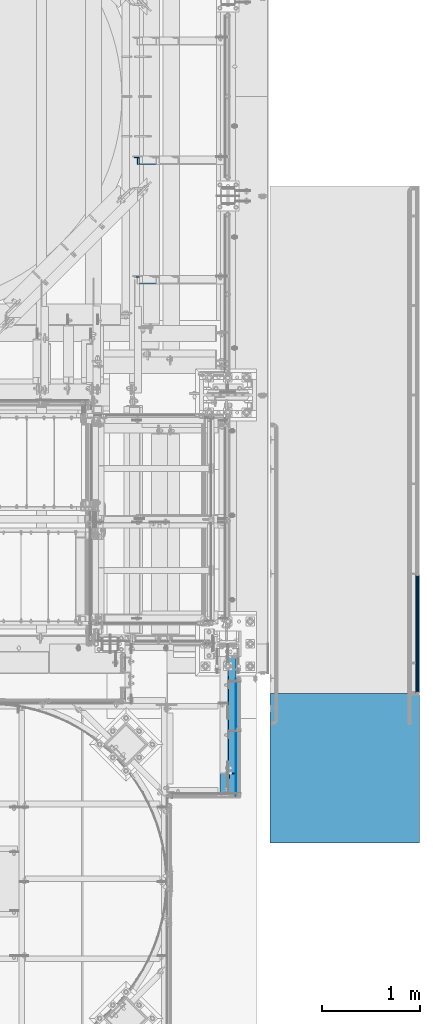
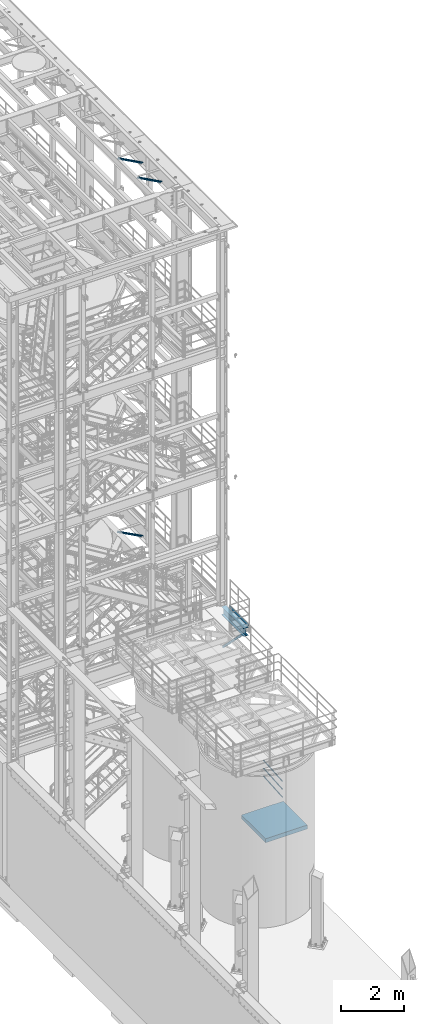
# One storey, part 998 of 1876: 6 beams, 4 members, 8 elements without a shape of their own.
"""IFC2X3 building model written with IfcOpenShell, lengths in millimetres."""

from ifc_helpers import new_model, si_unit, frame, origin_with_axes, place, context, subcontext, project, spatial, faceted_brep, material, type_object, element, aggregate, save


model = new_model("IFC2X3")

# Units and contexts
model_context = context("Model", 3, precision=1e-05, world=origin_with_axes())
body_context = subcontext(model_context, "Body", "Model", "MODEL_VIEW")
ifc_project = project(units=[si_unit("LENGTHUNIT", "METRE", prefix="MILLI"), si_unit("AREAUNIT", "SQUARE_METRE"), si_unit("VOLUMEUNIT", "CUBIC_METRE"), si_unit("MASSUNIT", "GRAM", prefix="KILO"), si_unit("TIMEUNIT", "SECOND"), si_unit("PLANEANGLEUNIT", "RADIAN"), si_unit("SOLIDANGLEUNIT", "STERADIAN"), si_unit("THERMODYNAMICTEMPERATUREUNIT", "DEGREE_CELSIUS"), si_unit("LUMINOUSINTENSITYUNIT", "LUMEN")], contexts=[model_context])

# Site, building, storey
site_placement = place(None, origin_with_axes())
site = spatial("IfcSite", under=ifc_project, at=site_placement, CompositionType="ELEMENT")
building_placement = place(site_placement, origin_with_axes())
building = spatial("IfcBuilding", under=site, at=building_placement, Name="Undefined", CompositionType="ELEMENT")
storey_placement = place(building_placement, origin_with_axes())
storey = spatial("IfcBuildingStorey", under=building, at=storey_placement, Name="Undefined", CompositionType="ELEMENT", Elevation=0.0)

# Assembly, beam
assembly_1_placement = place(storey_placement, origin_with_axes())
assembly_1 = element("IfcElementAssembly", 1, at=assembly_1_placement, inside=storey, Name="HANDRAIL", AssemblyPlace="NOTDEFINED", PredefinedType="RIGID_FRAME")
ifc_material_1 = material(Name="STEEL/A36")
beam_type_1 = type_object("IfcBeamType", PredefinedType="NOTDEFINED")
beam_1_placement = place(assembly_1_placement, frame((7705.725, -8663.432, 8080.375), z_axis=(0.0, 0.0, 1.0), x_axis=(0.0, 1.0, 0.0)))
beam_1 = element("IfcBeam", 2, at=beam_1_placement, type_object=beam_type_1, material=ifc_material_1, Name="PLATE", context=body_context, shape_type="Brep", body=[
    faceted_brep([(0.0, 3.17500000000018, -50.8000000000002), (0.0, 3.17500000000018, 50.8000000000002), (1194.24450076294, 3.17500000000018, 50.8000000000002), (1194.24450076294, 3.17500000000018, -50.8000000000002), (0.0, -3.17500000000018, 50.8000000000002), (1194.24450076294, -3.17500000000018, 50.8000000000002), (0.0, -3.17500000000018, -50.8000000000002), (1194.24450076294, -3.17500000000018, -50.8000000000002)], [[[0, 1, 2, 3]], [[1, 4, 5, 2]], [[4, 6, 7, 5]], [[6, 0, 3, 7]], [[5, 7, 3, 2]], [[6, 4, 1, 0]]]),
])
aggregate(assembly_1, [beam_1])

# Assembly, member
assembly_2_placement = place(storey_placement, origin_with_axes())
assembly_2 = element("IfcElementAssembly", 3, at=assembly_2_placement, inside=storey, Name="ANGLE", AssemblyPlace="NOTDEFINED", PredefinedType="RIGID_FRAME")
member_type = type_object("IfcMemberType", Name="L3X3X3/8", PredefinedType="NOTDEFINED")
member_1_placement = place(assembly_2_placement, frame((7662.86250005337, -8459.78750000608, 7640.6375), z_axis=(1.0, 0.0, 0.0), x_axis=(0.0, 0.707106781186548, -0.707106781186548)))
member_1 = element("IfcMember", 4, at=member_1_placement, type_object=member_type, material=ifc_material_1, Name="ANGLE", ObjectType="L3X3X3/8", context=body_context, shape_type="Brep", body=[
    faceted_brep([(0.0, 38.1000000000004, -38.1), (0.0, 38.1000000000004, 38.1), (1831.97224869938, 38.1000000000057, 38.1000000000004), (1831.97224869938, 38.1000000000057, -38.1000000000004), (0.0, 28.5749999999998, 38.1), (1831.97224869938, 28.5750000000043, 38.1000000000004), (0.0, 28.5749999999998, -28.575), (1831.97224869938, 28.5750000000043, -28.5749999999998), (0.0, -38.1000000000004, -28.575), (1831.97224869938, -38.1000000000068, -28.5749999999998), (0.0, -38.1000000000004, -38.1), (1831.97224869938, -38.1000000000068, -38.1000000000004)], [[[0, 1, 2, 3]], [[1, 4, 5, 2]], [[4, 6, 7, 5]], [[6, 8, 9, 7]], [[8, 10, 11, 9]], [[10, 0, 3, 11]], [[5, 7, 9, 11, 3, 2]], [[10, 8, 6, 4, 1, 0]]]),
])
aggregate(assembly_2, [member_1])

assembly_3_placement = place(storey_placement, origin_with_axes())
assembly_3 = element("IfcElementAssembly", 5, at=assembly_3_placement, inside=storey, AssemblyPlace="NOTDEFINED", PredefinedType="RIGID_FRAME")
member_2_placement = place(assembly_3_placement, frame((6618.98281309327, -2181.225, 8122.54466495056), z_axis=(0.0, -1.0, 0.0), x_axis=(0.882670061850832, 0.0, -0.469993150920573)))
member_2 = element("IfcMember", 6, at=member_2_placement, type_object=member_type, material=ifc_material_1, ObjectType="L3X3X3/8", context=body_context, shape_type="Brep", body=[
    faceted_brep([(70.0788597189262, 38.1000000000258, -38.1), (70.0788597189262, 38.1000000000258, 38.1), (1091.31003699859, 38.1000000003387, 38.1), (1091.31003699859, 38.1000000003387, -38.1), (70.0788597189253, 28.5750000000244, 38.1), (1091.31003699859, 28.5750000003391, 38.1), (70.0788597189253, 28.5750000000244, -28.575), (1091.31003699859, 28.5750000003391, -28.575), (70.0788597189262, -38.0999999999822, -28.575), (1091.31003699859, -38.0999999996675, -28.575), (70.0788597189262, -38.0999999999822, -38.1), (1091.31003699859, -38.0999999996675, -38.1)], [[[0, 1, 2, 3]], [[1, 4, 5, 2]], [[4, 6, 7, 5]], [[6, 8, 9, 7]], [[8, 10, 11, 9]], [[10, 0, 3, 11]], [[5, 7, 9, 11, 3, 2]], [[10, 8, 6, 4, 1, 0]]]),
])
aggregate(assembly_3, [member_2])

assembly_4_placement = place(storey_placement, origin_with_axes())
assembly_4 = element("IfcElementAssembly", 7, at=assembly_4_placement, inside=storey, AssemblyPlace="NOTDEFINED", PredefinedType="RIGID_FRAME")
member_3_placement = place(assembly_4_placement, frame((6649.22451200435, -3400.425, 22521.7692276093), z_axis=(0.0, -1.0, 0.0), x_axis=(0.877448093107094, 0.0, -0.479671600058544)))
member_3 = element("IfcMember", 8, at=member_3_placement, type_object=member_type, material=ifc_material_1, ObjectType="L3X3X3/8", context=body_context, shape_type="Brep", body=[
    faceted_brep([(59.7482362440578, 38.0999999998749, -38.0999999999999), (59.7482362440578, 38.0999999998749, 38.0999999999999), (1062.91900040893, 38.0999999984488, 38.0999999999999), (1062.91900040893, 38.0999999984488, -38.0999999999999), (59.7482362440696, 28.5749999998843, 38.0999999999999), (1062.91900040895, 28.5749999984582, 38.0999999999999), (59.7482362440696, 28.5749999998843, -28.5749999999998), (1062.91900040895, 28.5749999984582, -28.5749999999998), (59.7482362441442, -38.1000000000495, -28.5749999999998), (1062.91900040902, -38.1000000014719, -28.5749999999998), (59.7482362441442, -38.1000000000495, -38.0999999999999), (1062.91900040902, -38.1000000014719, -38.0999999999999)], [[[0, 1, 2, 3]], [[1, 4, 5, 2]], [[4, 6, 7, 5]], [[6, 8, 9, 7]], [[8, 10, 11, 9]], [[10, 0, 3, 11]], [[5, 7, 9, 11, 3, 2]], [[10, 8, 6, 4, 1, 0]]]),
])
aggregate(assembly_4, [member_3])

assembly_5_placement = place(storey_placement, origin_with_axes())
assembly_5 = element("IfcElementAssembly", 9, at=assembly_5_placement, inside=storey, AssemblyPlace="NOTDEFINED", PredefinedType="RIGID_FRAME")
member_4_placement = place(assembly_5_placement, frame((6649.22451200435, -2181.225, 22521.7692276093), z_axis=(0.0, -1.0, 0.0), x_axis=(0.877448093107094, 0.0, -0.479671600058544)))
member_4 = element("IfcMember", 10, at=member_4_placement, type_object=member_type, material=ifc_material_1, ObjectType="L3X3X3/8", context=body_context, shape_type="Brep", body=[
    faceted_brep([(59.7482362440578, 38.0999999998749, -38.0999999999999), (59.7482362440578, 38.0999999998749, 38.0999999999999), (1062.91900040893, 38.0999999984488, 38.0999999999999), (1062.91900040893, 38.0999999984488, -38.0999999999999), (59.7482362440696, 28.5749999998843, 38.0999999999999), (1062.91900040895, 28.5749999984582, 38.0999999999999), (59.7482362440696, 28.5749999998843, -28.5749999999998), (1062.91900040895, 28.5749999984582, -28.5749999999998), (59.7482362441442, -38.1000000000495, -28.5749999999998), (1062.91900040902, -38.1000000014719, -28.5749999999998), (59.7482362441442, -38.1000000000495, -38.0999999999999), (1062.91900040902, -38.1000000014719, -38.0999999999999)], [[[0, 1, 2, 3]], [[1, 4, 5, 2]], [[4, 6, 7, 5]], [[6, 8, 9, 7]], [[8, 10, 11, 9]], [[10, 0, 3, 11]], [[5, 7, 9, 11, 3, 2]], [[10, 8, 6, 4, 1, 0]]]),
])
aggregate(assembly_5, [member_4])

# Assembly, beam
assembly_6_placement = place(storey_placement, origin_with_axes())
assembly_6 = element("IfcElementAssembly", 11, at=assembly_6_placement, inside=storey, Name="BEAM", AssemblyPlace="NOTDEFINED", PredefinedType="RIGID_FRAME")
ifc_material_2 = material(Name="STEEL/A992")
beam_type_2 = type_object("IfcBeamType", Name="W12X26", PredefinedType="NOTDEFINED")
beam_2_placement = place(assembly_6_placement, frame((7620.0, -8661.4, 7842.25), z_axis=(0.0, 0.0, 1.0), x_axis=(0.0, 1.0, 0.0)))
beam_2 = element("IfcBeam", 12, at=beam_2_placement, type_object=beam_type_2, material=ifc_material_2, Name="BEAM", ObjectType="W12X26", context=body_context, shape_type="Brep", body=[
    faceted_brep([(0.0, 82.5500000000002, -155.575), (0.0, 82.5500000000002, -146.05), (1406.525, 82.5500000000002, -146.05), (1406.525, 82.5500000000002, -155.575), (0.0, 3.17500000000018, -146.05), (1406.525, 3.17500000000018, -146.05), (0.0, 3.17500000000018, 146.05), (1406.525, 3.17500000000018, 146.05), (0.0, 82.5500000000002, 146.05), (1406.525, 82.5500000000002, 146.05), (0.0, 82.5500000000002, 155.575), (1406.525, 82.5500000000002, 155.575), (0.0, -82.5500000000002, 155.575), (1406.525, -82.5500000000002, 155.575), (0.0, -82.5500000000002, 146.05), (1406.525, -82.5500000000002, 146.05), (0.0, -3.17500000000018, 146.05), (1406.525, -3.17500000000018, 146.05), (0.0, -3.17500000000018, -146.05), (1406.525, -3.17500000000018, -146.05), (0.0, -82.5500000000002, -146.05), (1406.525, -82.5500000000002, -146.05), (0.0, -82.5500000000002, -155.575), (1406.525, -82.5500000000002, -155.575)], [[[0, 1, 2, 3]], [[1, 4, 5, 2]], [[4, 6, 7, 5]], [[6, 8, 9, 7]], [[8, 10, 11, 9]], [[10, 12, 13, 11]], [[12, 14, 15, 13]], [[14, 16, 17, 15]], [[16, 18, 19, 17]], [[18, 20, 21, 19]], [[20, 22, 23, 21]], [[22, 0, 3, 23]], [[5, 7, 9, 11, 13, 15, 17, 19, 21, 23, 3, 2]], [[22, 20, 18, 16, 14, 12, 10, 8, 6, 4, 1, 0]]]),
])
aggregate(assembly_6, [beam_2])

# Assembly, beams
assembly_7_placement = place(storey_placement, origin_with_axes())
assembly_7 = element("IfcElementAssembly", 13, at=assembly_7_placement, inside=storey, Name="RAIL", AssemblyPlace="NOTDEFINED", PredefinedType="RIGID_FRAME")
ifc_material_3 = material()
beam_type_3 = type_object("IfcBeamType", PredefinedType="NOTDEFINED")
beam_3_placement = place(assembly_7_placement, frame((9556.75019531245, -7620.00000000011, 152.399999999655), z_axis=(0.0, -0.072723596972548, 0.997352133623513), x_axis=(0.0, 0.997352133623513, 0.0727235969725478)))
beam_3 = element("IfcBeam", 14, at=beam_3_placement, type_object=beam_type_3, material=ifc_material_3, Name="RAIL", context=body_context, shape_type="Brep", body=[
    faceted_brep([(1207.0982290601, -9.52499999999964, 16.497783942101), (1206.78197993275, -9.52500000005239, 12.1606532850326), (1206.47123649284, -7.9375, 13.7481532850854), (1204.49382580197, 0.0, 15.8750000000074), (1204.72533623104, 0.0, 19.0500000000073), (1206.47123649287, 7.9375, 13.7481532850854), (1206.78197993276, 9.52499999994689, 12.1606532851381), (1207.0982290601, 9.52499999999964, 16.497783942101), (1222.43684945429, 19.0499999999993, 7.61701812734827e-12), (1213.58109283001, 16.4977839420935, 9.52500000000748), (1212.1920302556, 16.4977839420935, -9.52499999999236), (1210.70840697457, 13.7481532850779, 7.9375000000075), (1212.26212417405, 15.875, 7.50333128962666e-12), (1209.55085482922, 13.7481532850779, -7.9374999999925), (1205.00855123367, 9.52499999994689, -12.1606532851231), (1204.69230210633, 9.52499999999964, -16.497783942086), (1204.46629736472, 7.9375, -13.7481532850704), (1202.17872151129, 0.0, -15.8749999999924), (1201.94721108222, 0.0, -19.0499999999925), (1205.00855123368, -9.52500000005239, -12.1606532850176), (1204.69230210633, -9.52499999999964, -16.497783942086), (1204.4662973647, -7.9375, -13.7481532850704), (1222.43684942911, -19.050000000052, 1.84320469998056e-09), (1212.1920302556, -16.4977839420935, -9.52499999999247), (1213.58109283001, -16.4977839420935, 9.52500000000748), (1209.55085482912, -13.7481532850779, -7.9374999999925), (1212.26212417395, -15.875, 7.50333128962666e-12), (1210.70840697446, -13.7481532850779, 7.9375000000075), (8.85575659753249, -16.4977839420935, -9.52499999999998), (15.3386203674418, -9.52499999999964, -16.4977839420934), (-9.09494701772928e-13, 19.05, -1.81898940354586e-12), (8.85575659753249, 16.4977839420935, -9.52499999999998), (10.244819171945, 16.4977839420935, 9.52499999999998), (17.7445473212156, 9.52499999999964, 16.4977839420935), (20.489638345327, -1.41153577715158e-09, 19.05), (15.3386203674418, 9.52499999999964, -16.4977839420934), (17.7115131965011, 0.0, -19.0499999999998), (17.9430236255703, 0.0, -15.8749999999998), (15.6548694948933, -9.52500000141117, -12.1606532836663), (15.9656129350642, -7.9375, -13.7481532850779), (15.9656129343048, 7.9375, -13.7481532850778), (15.6548694946878, 9.5249999985881, -12.1606532864894), (11.7284424516083, 13.7481532850779, -7.9375), (10.1747252521245, 15.875, 0.0), (12.8859945969516, 13.7481532850779, 7.9375), (17.4282981939696, 9.5249999985881, 12.1606532864895), (17.9705520624493, 7.9375, 13.7481532850779), (20.2581279162578, -1.41153577715158e-09, 15.875), (17.9705520632106, -7.9375, 13.7481532850779), (17.428298193764, -9.52500000141117, 12.1606532836664), (17.7445473212156, -9.52499999999964, 16.4977839420935), (10.244819171945, -16.4977839420935, 9.52499999999998), (0.0, -19.0500000000002, 0.0), (12.8859945997865, -13.7481532850779, 7.9375), (10.1747252549585, -15.875, 0.0), (11.7284424544423, -13.7481532850779, -7.9375)], [[[0, 1, 2, 3, 4]], [[4, 3, 5, 6, 7]], [[8, 9, 10]], [[7, 6, 11, 12, 13, 14, 15, 10, 9]], [[16, 17, 18, 15, 14]], [[19, 20, 18, 17, 21]], [[22, 23, 24]], [[24, 23, 20, 19, 25, 26, 27, 1, 0]], [[28, 29, 20, 23]], [[30, 31, 32]], [[33, 34, 4, 7]], [[32, 33, 7, 9]], [[30, 32, 9, 8]], [[31, 30, 8, 10]], [[35, 31, 10, 15]], [[36, 35, 15, 18]], [[29, 36, 18, 20]], [[37, 36, 29, 38, 39]], [[40, 41, 35, 36, 37]], [[32, 31, 35, 41, 42, 43, 44, 45, 33]], [[33, 45, 46, 47, 34]], [[34, 47, 48, 49, 50]], [[34, 50, 0, 4]], [[50, 51, 24, 0]], [[51, 52, 22, 24]], [[52, 28, 23, 22]], [[51, 28, 52]], [[50, 49, 53, 54, 55, 38, 29, 28, 51]], [[55, 54, 26, 25]], [[21, 39, 38, 55, 25, 19]], [[37, 39, 21, 17]], [[40, 37, 17, 16]], [[42, 41, 40, 16, 14, 13]], [[43, 42, 13, 12]], [[44, 43, 12, 11]], [[5, 46, 45, 44, 11, 6]], [[47, 46, 5, 3]], [[48, 47, 3, 2]], [[53, 49, 48, 2, 1, 27]], [[54, 53, 27, 26]]]),
])
ifc_material_4 = material()
beam_4_placement = place(assembly_7_placement, frame((9556.75019531097, -6400.80000000011, 546.100005085843), z_axis=(0.0, 0.072723596972548, -0.997352133623513), x_axis=(0.0, -0.997352133623513, -0.0727235969725479)))
beam_4 = element("IfcBeam", 15, at=beam_4_placement, type_object=beam_type_3, material=ifc_material_4, Name="RAIL", context=body_context, shape_type="Brep", body=[
    faceted_brep([(-9.09494701772928e-13, 19.05, -1.81898940354586e-12), (8.85575659753249, 16.4977839420935, -9.52499999999998), (10.244819171945, 16.4977839420935, 9.52499999999998), (10.244819171945, -16.4977839420935, 9.52499999999998), (8.85575659753249, -16.4977839420935, -9.52499999999998), (0.0, -19.0500000000002, 0.0), (17.7445473212156, -9.52499999999964, 16.4977839420935), (17.428298193764, -9.52500000141117, 12.1606532836664), (12.8859945997865, -13.7481532850779, 7.9375), (10.1747252549585, -15.875, 0.0), (11.7284424544423, -13.7481532850779, -7.9375), (15.6548694948933, -9.52500000141117, -12.1606532836663), (15.3386203674418, -9.52499999999964, -16.4977839420934), (17.9430236255703, 0.0, -15.8749999999998), (17.7115131965011, 0.0, -19.0499999999998), (15.9656129350642, -7.9375, -13.7481532850779), (15.9656129343048, 7.9375, -13.7481532850778), (15.6548694946878, 9.5249999985881, -12.1606532864894), (15.3386203674418, 9.52499999999964, -16.4977839420934), (11.7284424516083, 13.7481532850779, -7.9375), (10.1747252521245, 15.875, 0.0), (12.8859945969516, 13.7481532850779, 7.9375), (17.4282981939696, 9.5249999985881, 12.1606532864895), (17.7445473212156, 9.52499999999964, 16.4977839420935), (17.9705520624493, 7.9375, 13.7481532850779), (20.2581279162578, -1.41153577715158e-09, 15.875), (20.489638345327, -1.41153577715158e-09, 19.05), (17.9705520632106, -7.9375, 13.7481532850779), (1222.43684945429, 19.0499999999993, 7.61701812734827e-12), (1212.1920302556, 16.4977839420935, -9.52499999999236), (1204.69230210633, 9.52499999999964, -16.497783942086), (1222.43684942911, -19.050000000052, 1.84320469998056e-09), (1212.1920302556, -16.4977839420935, -9.52499999999247), (1213.58109283001, -16.4977839420935, 9.52500000000748), (1207.0982290601, -9.52499999999964, 16.497783942101), (1204.69230210633, -9.52499999999964, -16.497783942086), (1201.94721108222, 0.0, -19.0499999999925), (1204.46629736472, 7.9375, -13.7481532850704), (1202.17872151129, 0.0, -15.8749999999924), (1205.00855123367, 9.52499999994689, -12.1606532851231), (1205.00855123368, -9.52500000005239, -12.1606532850176), (1204.4662973647, -7.9375, -13.7481532850704), (1209.55085482912, -13.7481532850779, -7.9374999999925), (1212.26212417395, -15.875, 7.50333128962666e-12), (1210.70840697446, -13.7481532850779, 7.9375000000075), (1206.78197993275, -9.52500000005239, 12.1606532850326), (1206.47123649284, -7.9375, 13.7481532850854), (1204.49382580197, 0.0, 15.8750000000074), (1204.72533623104, 0.0, 19.0500000000073), (1207.0982290601, 9.52499999999964, 16.497783942101), (1213.58109283001, 16.4977839420935, 9.52500000000748), (1206.78197993276, 9.52499999994689, 12.1606532851381), (1210.70840697457, 13.7481532850779, 7.9375000000075), (1212.26212417405, 15.875, 7.50333128962666e-12), (1209.55085482922, 13.7481532850779, -7.9374999999925), (1206.47123649287, 7.9375, 13.7481532850854)], [[[0, 1, 2]], [[3, 4, 5]], [[6, 7, 8, 9, 10, 11, 12, 4, 3]], [[13, 14, 12, 11, 15]], [[16, 17, 18, 14, 13]], [[2, 1, 18, 17, 19, 20, 21, 22, 23]], [[23, 22, 24, 25, 26]], [[26, 25, 27, 7, 6]], [[1, 0, 28, 29]], [[18, 1, 29, 30]], [[31, 32, 33]], [[6, 3, 33, 34]], [[3, 5, 31, 33]], [[5, 4, 32, 31]], [[4, 12, 35, 32]], [[12, 14, 36, 35]], [[14, 18, 30, 36]], [[37, 38, 36, 30, 39]], [[40, 35, 36, 38, 41]], [[33, 32, 35, 40, 42, 43, 44, 45, 34]], [[34, 45, 46, 47, 48]], [[26, 6, 34, 48]], [[2, 23, 49, 50]], [[23, 26, 48, 49]], [[0, 2, 50, 28]], [[28, 50, 29]], [[49, 51, 52, 53, 54, 39, 30, 29, 50]], [[48, 47, 55, 51, 49]], [[25, 24, 55, 47]], [[55, 24, 22, 21, 52, 51]], [[21, 20, 53, 52]], [[20, 19, 54, 53]], [[19, 17, 16, 37, 39, 54]], [[16, 13, 38, 37]], [[13, 15, 41, 38]], [[41, 15, 11, 10, 42, 40]], [[10, 9, 43, 42]], [[9, 8, 44, 43]], [[8, 7, 27, 46, 45, 44]], [[27, 25, 47, 46]]]),
])
beam_5_placement = place(assembly_7_placement, frame((9556.75019531103, -6400.80000000011, 850.900005086281), z_axis=(0.0, 0.072723596972548, -0.997352133623513), x_axis=(0.0, -0.997352133623513, -0.0727235969725479)))
beam_5 = element("IfcBeam", 16, at=beam_5_placement, type_object=beam_type_3, material=ifc_material_4, Name="RAIL", context=body_context, shape_type="Brep", body=[
    faceted_brep([(-9.09494701772928e-13, 19.05, -1.81898940354586e-12), (8.85575659753249, 16.4977839420935, -9.52499999999998), (10.244819171945, 16.4977839420935, 9.52499999999998), (10.244819171945, -16.4977839420935, 9.52499999999998), (8.85575659753249, -16.4977839420935, -9.52499999999998), (0.0, -19.0500000000002, 0.0), (17.7445473212156, -9.52499999999964, 16.4977839420935), (17.428298193764, -9.52500000141117, 12.1606532836664), (12.8859945997865, -13.7481532850779, 7.9375), (10.1747252549585, -15.875, 0.0), (11.7284424544423, -13.7481532850779, -7.9375), (15.6548694948933, -9.52500000141117, -12.1606532836663), (15.3386203674418, -9.52499999999964, -16.4977839420934), (17.9430236255703, 0.0, -15.8749999999998), (17.7115131965011, 0.0, -19.0499999999998), (15.9656129350642, -7.9375, -13.7481532850779), (15.9656129343048, 7.9375, -13.7481532850778), (15.6548694946878, 9.5249999985881, -12.1606532864894), (15.3386203674418, 9.52499999999964, -16.4977839420934), (11.7284424516083, 13.7481532850779, -7.9375), (10.1747252521245, 15.875, 0.0), (12.8859945969516, 13.7481532850779, 7.9375), (17.4282981939696, 9.5249999985881, 12.1606532864895), (17.7445473212156, 9.52499999999964, 16.4977839420935), (17.9705520624493, 7.9375, 13.7481532850779), (20.2581279162578, -1.41153577715158e-09, 15.875), (20.489638345327, -1.41153577715158e-09, 19.05), (17.9705520632106, -7.9375, 13.7481532850779), (1222.43684945429, 19.0499999999993, 7.61701812734827e-12), (1212.1920302556, 16.4977839420935, -9.52499999999236), (1204.69230210633, 9.52499999999964, -16.497783942086), (1222.43684942911, -19.050000000052, 1.84320469998056e-09), (1212.1920302556, -16.4977839420935, -9.52499999999247), (1213.58109283001, -16.4977839420935, 9.52500000000748), (1207.0982290601, -9.52499999999964, 16.497783942101), (1204.69230210633, -9.52499999999964, -16.497783942086), (1201.94721108222, 0.0, -19.0499999999925), (1204.46629736472, 7.9375, -13.7481532850704), (1202.17872151129, 0.0, -15.8749999999924), (1205.00855123367, 9.52499999994689, -12.1606532851231), (1205.00855123368, -9.52500000005239, -12.1606532850176), (1204.4662973647, -7.9375, -13.7481532850704), (1209.55085482912, -13.7481532850779, -7.9374999999925), (1212.26212417395, -15.875, 7.50333128962666e-12), (1210.70840697446, -13.7481532850779, 7.9375000000075), (1206.78197993275, -9.52500000005239, 12.1606532850326), (1206.47123649284, -7.9375, 13.7481532850854), (1204.49382580197, 0.0, 15.8750000000074), (1204.72533623104, 0.0, 19.0500000000073), (1207.0982290601, 9.52499999999964, 16.497783942101), (1213.58109283001, 16.4977839420935, 9.52500000000748), (1206.78197993276, 9.52499999994689, 12.1606532851381), (1210.70840697457, 13.7481532850779, 7.9375000000075), (1212.26212417405, 15.875, 7.50333128962666e-12), (1209.55085482922, 13.7481532850779, -7.9374999999925), (1206.47123649287, 7.9375, 13.7481532850854)], [[[0, 1, 2]], [[3, 4, 5]], [[6, 7, 8, 9, 10, 11, 12, 4, 3]], [[13, 14, 12, 11, 15]], [[16, 17, 18, 14, 13]], [[2, 1, 18, 17, 19, 20, 21, 22, 23]], [[23, 22, 24, 25, 26]], [[26, 25, 27, 7, 6]], [[1, 0, 28, 29]], [[18, 1, 29, 30]], [[31, 32, 33]], [[6, 3, 33, 34]], [[3, 5, 31, 33]], [[5, 4, 32, 31]], [[4, 12, 35, 32]], [[12, 14, 36, 35]], [[14, 18, 30, 36]], [[37, 38, 36, 30, 39]], [[40, 35, 36, 38, 41]], [[33, 32, 35, 40, 42, 43, 44, 45, 34]], [[34, 45, 46, 47, 48]], [[26, 6, 34, 48]], [[2, 23, 49, 50]], [[23, 26, 48, 49]], [[0, 2, 50, 28]], [[28, 50, 29]], [[49, 51, 52, 53, 54, 39, 30, 29, 50]], [[48, 47, 55, 51, 49]], [[25, 24, 55, 47]], [[55, 24, 22, 21, 52, 51]], [[21, 20, 53, 52]], [[20, 19, 54, 53]], [[19, 17, 16, 37, 39, 54]], [[16, 13, 38, 37]], [[13, 15, 41, 38]], [[41, 15, 11, 10, 42, 40]], [[10, 9, 43, 42]], [[9, 8, 44, 43]], [[8, 7, 27, 46, 45, 44]], [[27, 25, 47, 46]]]),
])
aggregate(assembly_7, [beam_3, beam_4, beam_5])

# Assembly, beam
assembly_8_placement = place(storey_placement, origin_with_axes())
assembly_8 = element("IfcElementAssembly", 17, at=assembly_8_placement, inside=storey, Name="BEAM", AssemblyPlace="NOTDEFINED", PredefinedType="REINFORCEMENT_UNIT")
ifc_material_5 = material(Name="CONCRETE/5000")
beam_type_4 = type_object("IfcBeamType", PredefinedType="NOTDEFINED")
beam_6_placement = place(assembly_8_placement, frame((8813.8001953125, -7620.0, -76.2), z_axis=(0.0, 0.0, 1.0), x_axis=(0.0, -1.0, 0.0)))
beam_6 = element("IfcBeam", 18, at=beam_6_placement, type_object=beam_type_4, material=ifc_material_5, Name="BEAM", context=body_context, shape_type="Brep", body=[
    faceted_brep([(0.0, 762.0, -76.2), (0.0, 762.0, 76.2), (1524.0, 762.0, 76.2), (1524.0, 762.0, -76.2), (0.0, -762.0, 76.2), (1524.0, -762.0, 76.2), (0.0, -762.0, -76.2), (1524.0, -762.0, -76.2)], [[[0, 1, 2, 3]], [[1, 4, 5, 2]], [[4, 6, 7, 5]], [[6, 0, 3, 7]], [[5, 7, 3, 2]], [[6, 4, 1, 0]]]),
])
aggregate(assembly_8, [beam_6])

save(model, "model.ifc")
